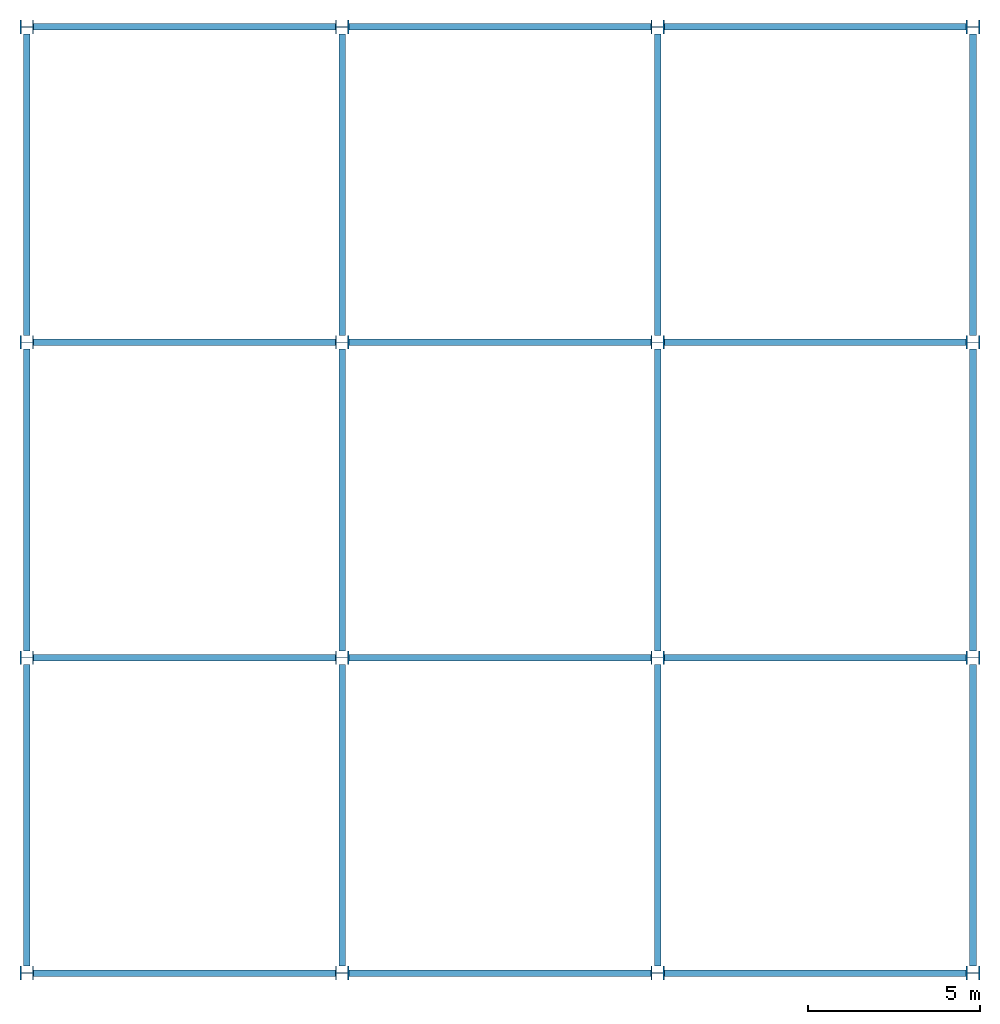
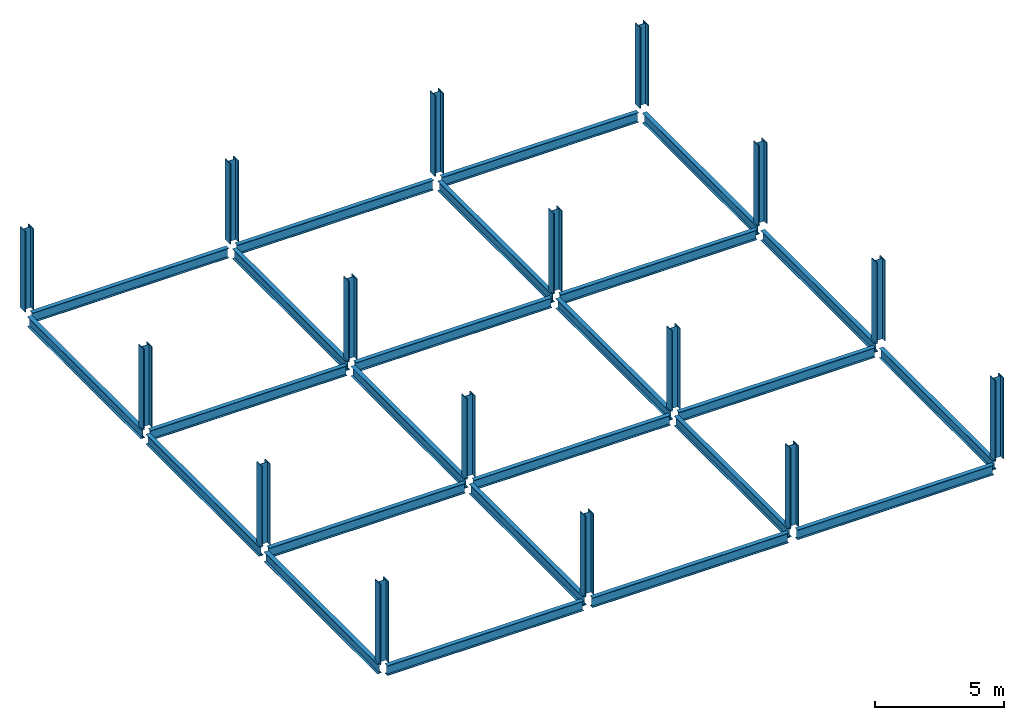
# One storey: 24 beams, 16 columns.
"""IFC2X3 building model written with IfcOpenShell, lengths in inches."""

from ifc_helpers import new_model, entity, si_unit, converted_unit, derived_unit, frame, origin_with_axes, origin_2d_with_axis, place, context, project, spatial, i_section, transform_2d, derived_profile, extrude, material, element, save


model = new_model("IFC2X3")

# Units and contexts
model_context = context("Model", 3, world=origin_with_axes())
ifc_project = project(units=[converted_unit("LENGTHUNIT", "INCH", entity("IfcLengthMeasure", 25.4), si_unit("LENGTHUNIT", "METRE", prefix="MILLI"), dimensions=[1, 0, 0, 0, 0, 0, 0]), converted_unit("AREAUNIT", "SQUARE INCH", entity("IfcAreaMeasure", 645.16), si_unit("AREAUNIT", "SQUARE_METRE", prefix="MICRO"), dimensions=[2, 0, 0, 0, 0, 0, 0]), converted_unit("VOLUMEUNIT", "CUBIC INCH", entity("IfcVolumeMeasure", 16387.064), si_unit("VOLUMEUNIT", "CUBIC_METRE", prefix="NANO"), dimensions=[3, 0, 0, 0, 0, 0, 0]), derived_unit("SECTIONMODULUSUNIT", [(converted_unit("LENGTHUNIT", "INCH", entity("IfcLengthMeasure", 25.4), si_unit("LENGTHUNIT", "METRE", prefix="MILLI"), dimensions=[1, 0, 0, 0, 0, 0, 0]), 3)]), derived_unit("MOMENTOFINERTIAUNIT", [(converted_unit("LENGTHUNIT", "INCH", entity("IfcLengthMeasure", 25.4), si_unit("LENGTHUNIT", "METRE", prefix="MILLI"), dimensions=[1, 0, 0, 0, 0, 0, 0]), 4)]), si_unit("PLANEANGLEUNIT", "RADIAN"), si_unit("TIMEUNIT", "SECOND"), converted_unit("FORCEUNIT", "LBF", entity("IfcForceMeasure", 4.448222), si_unit("FORCEUNIT", "NEWTON"), dimensions=[1, 1, -2, 0, 0, 0, 0]), derived_unit("TORQUEUNIT", [(converted_unit("LENGTHUNIT", "INCH", entity("IfcLengthMeasure", 25.4), si_unit("LENGTHUNIT", "METRE", prefix="MILLI"), dimensions=[1, 0, 0, 0, 0, 0, 0]), 1), (converted_unit("FORCEUNIT", "LBF", entity("IfcForceMeasure", 4.448222), si_unit("FORCEUNIT", "NEWTON"), dimensions=[1, 1, -2, 0, 0, 0, 0]), 1)]), converted_unit("PRESSUREUNIT", "PSI", entity("IfcPressureMeasure", 6894.7579), si_unit("PRESSUREUNIT", "PASCAL"), dimensions=[-1, 1, -2, 0, 0, 0, 0]), derived_unit("LINEARFORCEUNIT", [(converted_unit("LENGTHUNIT", "INCH", entity("IfcLengthMeasure", 25.4), si_unit("LENGTHUNIT", "METRE", prefix="MILLI"), dimensions=[1, 0, 0, 0, 0, 0, 0]), -1), (converted_unit("FORCEUNIT", "LBF", entity("IfcForceMeasure", 4.448222), si_unit("FORCEUNIT", "NEWTON"), dimensions=[1, 1, -2, 0, 0, 0, 0]), 1)]), derived_unit("PLANARFORCEUNIT", [(converted_unit("LENGTHUNIT", "INCH", entity("IfcLengthMeasure", 25.4), si_unit("LENGTHUNIT", "METRE", prefix="MILLI"), dimensions=[1, 0, 0, 0, 0, 0, 0]), -2), (converted_unit("FORCEUNIT", "LBF", entity("IfcForceMeasure", 4.448222), si_unit("FORCEUNIT", "NEWTON"), dimensions=[1, 1, -2, 0, 0, 0, 0]), 1)]), derived_unit("LINEARMOMENTUNIT", [(converted_unit("FORCEUNIT", "LBF", entity("IfcForceMeasure", 4.448222), si_unit("FORCEUNIT", "NEWTON"), dimensions=[1, 1, -2, 0, 0, 0, 0]), 1), (converted_unit("LENGTHUNIT", "INCH", entity("IfcLengthMeasure", 25.4), si_unit("LENGTHUNIT", "METRE", prefix="MILLI"), dimensions=[1, 0, 0, 0, 0, 0, 0]), 1), (converted_unit("LENGTHUNIT", "INCH", entity("IfcLengthMeasure", 25.4), si_unit("LENGTHUNIT", "METRE", prefix="MILLI"), dimensions=[1, 0, 0, 0, 0, 0, 0]), -1)]), derived_unit("SHEARMODULUSUNIT", [(converted_unit("LENGTHUNIT", "INCH", entity("IfcLengthMeasure", 25.4), si_unit("LENGTHUNIT", "METRE", prefix="MILLI"), dimensions=[1, 0, 0, 0, 0, 0, 0]), -2), (converted_unit("FORCEUNIT", "LBF", entity("IfcForceMeasure", 4.448222), si_unit("FORCEUNIT", "NEWTON"), dimensions=[1, 1, -2, 0, 0, 0, 0]), 1)]), derived_unit("MODULUSOFELASTICITYUNIT", [(converted_unit("LENGTHUNIT", "INCH", entity("IfcLengthMeasure", 25.4), si_unit("LENGTHUNIT", "METRE", prefix="MILLI"), dimensions=[1, 0, 0, 0, 0, 0, 0]), -2), (converted_unit("FORCEUNIT", "LBF", entity("IfcForceMeasure", 4.448222), si_unit("FORCEUNIT", "NEWTON"), dimensions=[1, 1, -2, 0, 0, 0, 0]), 1)]), converted_unit("THERMODYNAMICTEMPERATUREUNIT", "FAHRENHEIT", entity("IfcThermodynamicTemperatureMeasure", 0.55555556), si_unit("THERMODYNAMICTEMPERATUREUNIT", "KELVIN"), dimensions=[0, 0, 0, 0, 1, 0, 0]), derived_unit("THERMALEXPANSIONCOEFFICIENTUNIT", [(converted_unit("THERMODYNAMICTEMPERATUREUNIT", "FAHRENHEIT", entity("IfcThermodynamicTemperatureMeasure", 0.55555556), si_unit("THERMODYNAMICTEMPERATUREUNIT", "KELVIN"), dimensions=[0, 0, 0, 0, 1, 0, 0]), -1)])], contexts=[model_context])

# Site, building, storey
site = spatial("IfcSite", under=ifc_project, CompositionType="ELEMENT")
building = spatial("IfcBuilding", under=site, Name="Default Building", CompositionType="ELEMENT")
storey = spatial("IfcBuildingStorey", under=building, Name="LEVEL 3", CompositionType="ELEMENT", Elevation=360.0)

# Columns
ifc_material = material(Name="A992Fy50")
for number, where, z_axis, x_axis, name in (
    (1, (0.0, 0.0, 360.0), (0.0, 0.0, 1.0), (0.0, -1.0, 0.0), "33"),
    (2, (0.0, 360.0, 360.0), (0.0, 0.0, 1.0), (0.0, -1.0, 0.0), "34"),
    (3, (0.0, 720.0, 360.0), (0.0, 0.0, 1.0), (0.0, -1.0, 0.0), "35"),
    (4, (0.0, 1080.0, 360.0), (0.0, 0.0, 1.0), (0.0, -1.0, 0.0), "36"),
    (5, (360.0, 0.0, 360.0), (0.0, 0.0, 1.0), (0.0, -1.0, 0.0), "37"),
    (6, (360.0, 360.0, 360.0), (0.0, 0.0, 1.0), (0.0, -1.0, 0.0), "38"),
    (7, (360.0, 720.0, 360.0), (0.0, 0.0, 1.0), (0.0, -1.0, 0.0), "39"),
    (8, (360.0, 1080.0, 360.0), (0.0, 0.0, 1.0), (0.0, -1.0, 0.0), "40"),
    (9, (720.0, 0.0, 360.0), (0.0, 0.0, 1.0), (0.0, -1.0, 0.0), "41"),
    (10, (720.0, 360.0, 360.0), (0.0, 0.0, 1.0), (0.0, -1.0, 0.0), "42"),
    (11, (720.0, 720.0, 360.0), (0.0, 0.0, 1.0), (0.0, -1.0, 0.0), "43"),
    (12, (720.0, 1080.0, 360.0), (0.0, 0.0, 1.0), (0.0, -1.0, 0.0), "44"),
    (13, (1080.0, 0.0, 360.0), (0.0, 0.0, 1.0), (0.0, -1.0, 0.0), "45"),
    (14, (1080.0, 360.0, 360.0), (0.0, 0.0, 1.0), (0.0, -1.0, 0.0), "46"),
    (15, (1080.0, 720.0, 360.0), (0.0, 0.0, 1.0), (0.0, -1.0, 0.0), "47"),
    (16, (1080.0, 1080.0, 360.0), (0.0, 0.0, 1.0), (0.0, -1.0, 0.0), "48"),
):
    element("IfcColumn", number, at=place(None, frame(where, z_axis=z_axis, x_axis=x_axis)), inside=storey, material=ifc_material, Name=name, context=model_context, shape_type="SweptSolid", body=[
        extrude(i_section(OverallWidth=15.7, OverallDepth=15.5, WebThickness=0.89, FlangeThickness=1.44, at=origin_2d_with_axis()), origin_with_axes(), (0.0, 0.0, 1.0), 149.9),
    ])

# Beams
for number, where, z_axis, x_axis, name in (
    (17, (0.0, 7.85, 360.0), (0.0, 1.0, 0.0), (-1.0, 0.0, 0.0), "73"),
    (18, (0.0, 367.85, 360.0), (0.0, 1.0, 0.0), (-1.0, 0.0, 0.0), "74"),
    (19, (0.0, 727.85, 360.0), (0.0, 1.0, 0.0), (-1.0, 0.0, 0.0), "75"),
    (20, (360.0, 7.85, 360.0), (0.0, 1.0, 0.0), (-1.0, 0.0, 0.0), "76"),
    (21, (360.0, 367.85, 360.0), (0.0, 1.0, 0.0), (-1.0, 0.0, 0.0), "77"),
    (22, (360.0, 727.85, 360.0), (0.0, 1.0, 0.0), (-1.0, 0.0, 0.0), "78"),
    (23, (720.0, 7.85, 360.0), (0.0, 1.0, 0.0), (-1.0, 0.0, 0.0), "79"),
    (24, (720.0, 367.85, 360.0), (0.0, 1.0, 0.0), (-1.0, 0.0, 0.0), "80"),
    (25, (720.0, 727.85, 360.0), (0.0, 1.0, 0.0), (-1.0, 0.0, 0.0), "81"),
    (26, (1080.0, 7.85, 360.0), (0.0, 1.0, 0.0), (-1.0, 0.0, 0.0), "82"),
    (27, (1080.0, 367.85, 360.0), (0.0, 1.0, 0.0), (-1.0, 0.0, 0.0), "83"),
    (28, (1080.0, 727.85, 360.0), (0.0, 1.0, 0.0), (-1.0, 0.0, 0.0), "84"),
):
    element("IfcBeam", number, at=place(None, frame(where, z_axis=z_axis, x_axis=x_axis)), inside=storey, material=ifc_material, Name=name, context=model_context, shape_type="SweptSolid", body=[
        extrude(derived_profile(i_section(OverallWidth=7.59, OverallDepth=18.4, WebThickness=0.45, FlangeThickness=0.75, at=origin_2d_with_axis()), transform_2d((0.0, -9.1999998))), origin_with_axes(), (0.0, 0.0, 1.0), 344.3),
    ])
for number, where, z_axis, x_axis, name in (
    (29, (7.75, 0.0, 360.0), (1.0, 0.0, 0.0), (0.0, 1.0, 0.0), "85"),
    (30, (367.75, 0.0, 360.0), (1.0, 0.0, 0.0), (0.0, 1.0, 0.0), "86"),
    (31, (727.75, 0.0, 360.0), (1.0, 0.0, 0.0), (0.0, 1.0, 0.0), "87"),
    (32, (7.75, 360.0, 360.0), (1.0, 0.0, 0.0), (0.0, 1.0, 0.0), "88"),
    (33, (367.75, 360.0, 360.0), (1.0, 0.0, 0.0), (0.0, 1.0, 0.0), "89"),
    (34, (727.75, 360.0, 360.0), (1.0, 0.0, 0.0), (0.0, 1.0, 0.0), "90"),
    (35, (7.75, 720.0, 360.0), (1.0, 0.0, 0.0), (0.0, 1.0, 0.0), "91"),
    (36, (367.75, 720.0, 360.0), (1.0, 0.0, 0.0), (0.0, 1.0, 0.0), "92"),
    (37, (727.75, 720.0, 360.0), (1.0, 0.0, 0.0), (0.0, 1.0, 0.0), "93"),
    (38, (7.75, 1080.0, 360.0), (1.0, 0.0, 0.0), (0.0, 1.0, 0.0), "94"),
    (39, (367.75, 1080.0, 360.0), (1.0, 0.0, 0.0), (0.0, 1.0, 0.0), "95"),
    (40, (727.75, 1080.0, 360.0), (1.0, 0.0, 0.0), (0.0, 1.0, 0.0), "96"),
):
    element("IfcBeam", number, at=place(None, frame(where, z_axis=z_axis, x_axis=x_axis)), inside=storey, material=ifc_material, Name=name, context=model_context, shape_type="SweptSolid", body=[
        extrude(derived_profile(i_section(OverallWidth=7.59, OverallDepth=18.4, WebThickness=0.45, FlangeThickness=0.75, at=origin_2d_with_axis()), transform_2d((0.0, -9.1999998))), origin_with_axes(), (0.0, 0.0, 1.0), 344.5),
    ])

save(model, "model.ifc")
